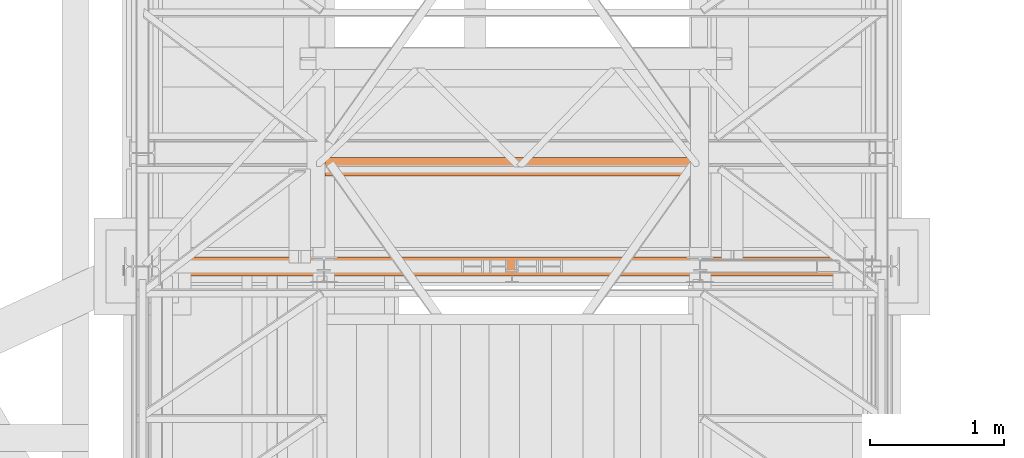
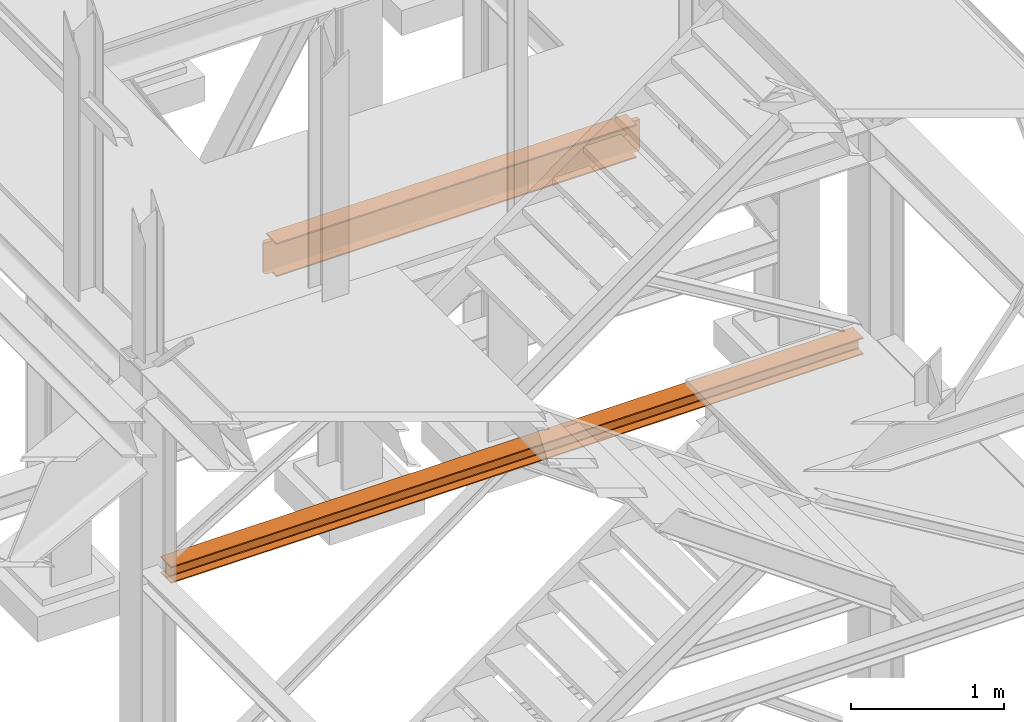
# One storey, part 54 of 208: 2 proxies.
"""IFC2X3 building model written with IfcOpenShell, lengths in millimetres."""

from ifc_helpers import new_model, entity, si_unit, converted_unit, frame, origin, origin_with_axes, place, context, subcontext, project, spatial, faceted_brep, element, save


model = new_model("IFC2X3")

# Units and contexts
model_context = context("Model", 3, precision=1e-05, world=origin())
plan_context = context("Plan", 3, precision=1e-05, world=origin())
body_context = subcontext(model_context, "Body", "Model", "MODEL_VIEW")
ifc_project = project(units=[si_unit("LENGTHUNIT", "METRE", prefix="MILLI"), converted_unit("PLANEANGLEUNIT", "DEGREE", entity("IfcPlaneAngleMeasure", 0.0174532925199433), si_unit("PLANEANGLEUNIT", "RADIAN"), dimensions=[0, 0, 0, 0, 0, 0, 0]), si_unit("AREAUNIT", "SQUARE_METRE"), si_unit("VOLUMEUNIT", "CUBIC_METRE")], contexts=[model_context, plan_context])

# Building, storey
building_placement = place(None, origin())
building = spatial("IfcBuilding", under=ifc_project, at=building_placement, CompositionType="COMPLEX")
storey_placement = place(building_placement, origin_with_axes())
storey = spatial("IfcBuildingStorey", under=building, at=storey_placement, Name="Geschoss", CompositionType="ELEMENT")

# Proxies
proxy_1_placement = place(storey_placement, frame((1333.254973893079, -22132.57439061591, 3447.489998909947), z_axis=(0.0, 0.0, 1.0), x_axis=(1.0, 0.0, 0.0)))
element("IfcBuildingElementProxy", 1, at=proxy_1_placement, inside=storey, context=body_context, shape_type="Brep", body=[
    faceted_brep([(0.01000000000021828, 0.01000000000567525, 8.510002324581365), (0.01000000000021828, 0.01000000000567525, 0.01000000000021828), (0.01000000000021828, 140.0100005960521, 0.01000000000021828), (0.01000000000021828, 140.0100005960521, 8.510002324581365), (0.01000000000021828, 84.76000038743587, 8.510002324581365), (0.01000000000021828, 78.54945996612878, 9.753034839630345), (0.01000000000021828, 74.00303279817672, 14.29946480155013), (0.01000000000021828, 72.76000051595838, 20.51000429153464), (0.01000000000021828, 72.76000051595838, 112.5100007450583), (0.01000000000021828, 74.00303279817672, 118.7205402350428), (0.01000000000021828, 78.54945996612878, 123.2669664716723), (0.01000000000021828, 84.76000038743587, 124.5099989867213), (0.01000000000021828, 140.0100005960521, 124.5099989867213), (0.01000000000021828, 140.0100005960521, 133.0100013113024), (0.01000000000021828, 0.01000000000567525, 133.0100013113024), (0.01000000000021828, 0.01000000000567525, 124.5099989867213), (0.01000000000021828, 55.26000020862193, 124.5099989867213), (0.01000000000021828, 61.47054062992902, 123.2669664716723), (0.01000000000021828, 66.01696779788108, 118.7205402350428), (0.01000000000021828, 67.26000008009942, 112.5100007450583), (0.01000000000021828, 67.26000008009942, 20.51000429153464), (0.01000000000021828, 66.01696779788108, 14.29946480155013), (0.01000000000021828, 61.47054062992902, 9.753034839630345), (0.01000000000021828, 55.26000020862193, 8.510002324581365), (0.01000000000021828, 0.01000000000567525, 0.01000000000021828), (0.01000000000021828, 0.01000000000567525, 8.510002324581365), (5230.009989271167, 0.01000000000203727, 8.510002324581365), (5230.009989271167, 0.01000000000203727, 0.01000000000021828), (0.01000000000021828, 140.0100005960521, 0.01000000000021828), (0.01000000000021828, 0.01000000000567525, 0.01000000000021828), (5230.009989271167, 0.01000000000203727, 0.01000000000021828), (5230.009989271167, 140.0100005960485, 0.01000000000021828), (0.01000000000021828, 140.0100005960521, 8.510002324581365), (0.01000000000021828, 140.0100005960521, 0.01000000000021828), (5230.009989271167, 140.0100005960485, 0.01000000000021828), (5230.009989271167, 140.0100005960485, 8.510002324581365), (0.01000000000021828, 84.76000038743587, 8.510002324581365), (0.01000000000021828, 140.0100005960521, 8.510002324581365), (5230.009989271167, 140.0100005960485, 8.510002324581365), (5230.009989271167, 84.76000038743223, 8.510002324581365), (0.01000000000021828, 78.54945996612878, 9.753034839630345), (0.01000000000021828, 84.76000038743587, 8.510002324581365), (5230.009989271167, 84.76000038743223, 8.510002324581365), (5230.009989271167, 78.54945996612514, 9.753034839630345), (0.01000000000021828, 74.00303279817672, 14.29946480155013), (0.01000000000021828, 78.54945996612878, 9.753034839630345), (5230.009989271167, 78.54945996612514, 9.753034839630345), (5230.009989271167, 74.00303279817308, 14.29946480155013), (0.01000000000021828, 72.76000051595838, 20.51000429153464), (0.01000000000021828, 74.00303279817672, 14.29946480155013), (5230.009989271167, 74.00303279817308, 14.29946480155013), (5230.009989271167, 72.76000051595474, 20.51000429153464), (0.01000000000021828, 72.76000051595838, 112.5100007450583), (0.01000000000021828, 72.76000051595838, 20.51000429153464), (5230.009989271167, 72.76000051595474, 20.51000429153464), (5230.009989271167, 72.76000051595474, 112.5100007450583), (0.01000000000021828, 74.00303279817672, 118.7205402350428), (0.01000000000021828, 72.76000051595838, 112.5100007450583), (5230.009989271167, 72.76000051595474, 112.5100007450583), (5230.009989271167, 74.00303279817308, 118.7205402350428), (0.01000000000021828, 78.54945996612878, 123.2669664716723), (0.01000000000021828, 74.00303279817672, 118.7205402350428), (5230.009989271167, 74.00303279817308, 118.7205402350428), (5230.009989271167, 78.54945996612514, 123.2669664716723), (0.01000000000021828, 84.76000038743587, 124.5099989867213), (0.01000000000021828, 78.54945996612878, 123.2669664716723), (5230.009989271167, 78.54945996612514, 123.2669664716723), (5230.009989271167, 84.76000038743223, 124.5099989867213), (0.01000000000021828, 140.0100005960521, 124.5099989867213), (0.01000000000021828, 84.76000038743587, 124.5099989867213), (5230.009989271167, 84.76000038743223, 124.5099989867213), (5230.009989271167, 140.0100005960485, 124.5099989867213), (0.01000000000021828, 140.0100005960521, 133.0100013113024), (0.01000000000021828, 140.0100005960521, 124.5099989867213), (5230.009989271167, 140.0100005960485, 124.5099989867213), (5230.009989271167, 140.0100005960485, 133.0100013113024), (0.01000000000021828, 0.01000000000567525, 133.0100013113024), (0.01000000000021828, 140.0100005960521, 133.0100013113024), (5230.009989271167, 140.0100005960485, 133.0100013113024), (5230.009989271167, 0.01000000000203727, 133.0100013113024), (0.01000000000021828, 0.01000000000567525, 124.5099989867213), (0.01000000000021828, 0.01000000000567525, 133.0100013113024), (5230.009989271167, 0.01000000000203727, 133.0100013113024), (5230.009989271167, 0.01000000000203727, 124.5099989867213), (0.01000000000021828, 55.26000020862193, 124.5099989867213), (0.01000000000021828, 0.01000000000567525, 124.5099989867213), (5230.009989271167, 0.01000000000203727, 124.5099989867213), (5230.009989271167, 55.26000020861829, 124.5099989867213), (0.01000000000021828, 61.47054062992902, 123.2669664716723), (0.01000000000021828, 55.26000020862193, 124.5099989867213), (5230.009989271167, 55.26000020861829, 124.5099989867213), (5230.009989271167, 61.47054062992538, 123.2669664716723), (0.01000000000021828, 66.01696779788108, 118.7205402350428), (0.01000000000021828, 61.47054062992902, 123.2669664716723), (5230.009989271167, 61.47054062992538, 123.2669664716723), (5230.009989271167, 66.01696779787744, 118.7205402350428), (0.01000000000021828, 67.26000008009942, 112.5100007450583), (0.01000000000021828, 66.01696779788108, 118.7205402350428), (5230.009989271167, 66.01696779787744, 118.7205402350428), (5230.009989271167, 67.26000008009578, 112.5100007450583), (0.01000000000021828, 67.26000008009942, 20.51000429153464), (0.01000000000021828, 67.26000008009942, 112.5100007450583), (5230.009989271167, 67.26000008009578, 112.5100007450583), (5230.009989271167, 67.26000008009578, 20.51000429153464), (0.01000000000021828, 66.01696779788108, 14.29946480155013), (0.01000000000021828, 67.26000008009942, 20.51000429153464), (5230.009989271167, 67.26000008009578, 20.51000429153464), (5230.009989271167, 66.01696779787744, 14.29946480155013), (0.01000000000021828, 61.47054062992902, 9.753034839630345), (0.01000000000021828, 66.01696779788108, 14.29946480155013), (5230.009989271167, 66.01696779787744, 14.29946480155013), (5230.009989271167, 61.47054062992538, 9.753034839630345), (0.01000000000021828, 55.26000020862193, 8.510002324581365), (0.01000000000021828, 61.47054062992902, 9.753034839630345), (5230.009989271167, 61.47054062992538, 9.753034839630345), (5230.009989271167, 55.26000020861829, 8.510002324581365), (0.01000000000021828, 0.01000000000567525, 8.510002324581365), (0.01000000000021828, 55.26000020862193, 8.510002324581365), (5230.009989271167, 55.26000020861829, 8.510002324581365), (5230.009989271167, 0.01000000000203727, 8.510002324581365), (5230.009989271167, 0.01000000000203727, 8.510002324581365), (5230.009989271167, 55.26000020861829, 8.510002324581365), (5230.009989271167, 61.47054062992538, 9.753034839630345), (5230.009989271167, 66.01696779787744, 14.29946480155013), (5230.009989271167, 67.26000008009578, 20.51000429153464), (5230.009989271167, 67.26000008009578, 112.5100007450583), (5230.009989271167, 66.01696779787744, 118.7205402350428), (5230.009989271167, 61.47054062992538, 123.2669664716723), (5230.009989271167, 55.26000020861829, 124.5099989867213), (5230.009989271167, 0.01000000000203727, 124.5099989867213), (5230.009989271167, 0.01000000000203727, 133.0100013113024), (5230.009989271167, 140.0100005960485, 133.0100013113024), (5230.009989271167, 140.0100005960485, 124.5099989867213), (5230.009989271167, 84.76000038743223, 124.5099989867213), (5230.009989271167, 78.54945996612514, 123.2669664716723), (5230.009989271167, 74.00303279817308, 118.7205402350428), (5230.009989271167, 72.76000051595474, 112.5100007450583), (5230.009989271167, 72.76000051595474, 20.51000429153464), (5230.009989271167, 74.00303279817308, 14.29946480155013), (5230.009989271167, 78.54945996612514, 9.753034839630345), (5230.009989271167, 84.76000038743223, 8.510002324581365), (5230.009989271167, 140.0100005960485, 8.510002324581365), (5230.009989271167, 140.0100005960485, 0.01000000000021828), (5230.009989271167, 0.01000000000203727, 0.01000000000021828)], [[[0, 1, 2, 3, 4, 5, 6, 7, 8, 9, 10, 11, 12, 13, 14, 15, 16, 17, 18, 19, 20, 21, 22, 23]], [[24, 25, 26, 27]], [[28, 29, 30, 31]], [[32, 33, 34, 35]], [[36, 37, 38, 39]], [[40, 41, 42, 43]], [[44, 45, 46, 47]], [[48, 49, 50, 51]], [[52, 53, 54, 55]], [[56, 57, 58, 59]], [[60, 61, 62, 63]], [[64, 65, 66, 67]], [[68, 69, 70, 71]], [[72, 73, 74, 75]], [[76, 77, 78, 79]], [[80, 81, 82, 83]], [[84, 85, 86, 87]], [[88, 89, 90, 91]], [[92, 93, 94, 95]], [[96, 97, 98, 99]], [[100, 101, 102, 103]], [[104, 105, 106, 107]], [[108, 109, 110, 111]], [[112, 113, 114, 115]], [[116, 117, 118, 119]], [[120, 121, 122, 123, 124, 125, 126, 127, 128, 129, 130, 131, 132, 133, 134, 135, 136, 137, 138, 139, 140, 141, 142, 143]]], orient=[[False], [False], [False], [False], [False], [False], [False], [False], [False], [False], [False], [False], [False], [False], [False], [False], [False], [False], [False], [False], [False], [False], [False], [False], [False], [False]]),
])
proxy_2_placement = place(storey_placement, frame((2493.538204317862, -21388.07439022289, 5014.990005364415), z_axis=(0.0, 0.0, 1.0), x_axis=(1.0, 0.0, 0.0)))
element("IfcBuildingElementProxy", 2, at=proxy_2_placement, inside=storey, context=body_context, shape_type="Brep", body=[
    faceted_brep([(2783.226764020814, 135.010000000002, 270.0100000000002), (64.21000004768484, 135.0100000000057, 270.0100000000002), (64.21000004768484, 135.0100000000057, 259.8100001907351), (2783.226764020813, 135.010000000002, 259.8100001907351), (2783.226764020813, 135.010000000002, 259.8100001907351), (64.21000004768484, 135.0100000000057, 259.8100001907351), (64.21000004768484, 85.80999995232196, 259.8100001907351), (2783.226764020813, 85.80999995231832, 259.8100001907351), (2832.426764068498, 85.80999995231832, 259.810000190736), (2783.226764020813, 85.80999995231832, 259.8100001907351), (64.21000004768484, 85.80999995232196, 259.8100001907351), (15.01000000000113, 85.80999995232196, 259.8100001907351), (10.37476080785655, 81.17476076017556, 259.0757968253238), (2837.062003260642, 81.17476076017556, 259.0757968253238), (2837.062003260642, 81.17476076017556, 259.0757968253238), (10.37476080785655, 81.17476076017556, 259.0757968253238), (6.193236074556808, 76.99323602687582, 256.9452365592933), (2841.243527993944, 76.99323602687582, 256.9452365592924), (2841.243527993944, 76.99323602687582, 256.9452365592924), (6.193236074556808, 76.99323602687582, 256.9452365592933), (2.874763631445603, 73.6747635837637, 253.6267641161803), (2844.562000437054, 73.6747635837637, 253.6267641161803), (2844.562000437054, 73.6747635837637, 253.6267641161803), (2.874763631445603, 73.6747635837637, 253.6267641161803), (0.7442033654124316, 71.54420331773144, 249.4452393828797), (2846.692560703086, 71.54420331773144, 249.4452393828797), (2846.692560703086, 71.54420331773144, 249.4452393828797), (0.7442033654124316, 71.54420331773144, 249.4452393828797), (0.01000000000112777, 70.80999995232196, 244.8100001907351), (2847.426764068498, 70.80999995231832, 244.8100001907351), (2847.426764068498, 70.80999995231832, 244.8100001907351), (0.01000000000112777, 70.80999995232196, 244.8100001907351), (0.01000000000112777, 70.80999995232196, 25.20999980926536), (2847.426764068498, 70.80999995231832, 25.20999980926536), (2847.426764068498, 70.80999995231832, 25.20999980926536), (0.01000000000112777, 70.80999995232196, 25.20999980926536), (0.7442033654124316, 71.54420331773144, 20.57476061712077), (2846.603718554712, 71.54420331773144, 20.57476061712077), (2846.915607506002, 71.42493642729096, 21.32772715327792), (2846.603718554712, 71.54420331773144, 20.57476061712077), (0.7442033654124316, 71.54420331773144, 20.57476061712077), (2.874763631444694, 73.6747635837637, 16.39323588382013), (2844.406723745758, 73.6747635837637, 16.39323588382013), (2845.41710483617, 73.00383809969208, 17.71002168452014), (2844.406723745758, 73.6747635837637, 16.39323588382013), (2.874763631444694, 73.6747635837637, 16.39323588382013), (6.193236074556808, 76.99323602687582, 13.07476344070892), (2841.041162624857, 76.99323602687582, 13.07476344070892), (2843.033365786296, 75.46460137611575, 14.60339809146717), (2841.041162624857, 76.99323602687582, 13.07476344070892), (6.193236074556808, 76.99323602687582, 13.07476344070892), (10.37476080785655, 81.17476076017556, 10.94420317467666), (2836.847519341127, 81.17476076017556, 10.94420317467666), (2839.926742193244, 78.67149890047949, 12.21965904159242), (2836.847519341127, 81.17476076017556, 10.94420317467666), (10.37476080785655, 81.17476076017556, 10.94420317467666), (15.01000000000113, 85.80999995232196, 10.20999980926536), (64.21000004768484, 85.80999995232196, 10.20999980926536), (2783.226764020814, 85.80999995231832, 10.20999980926536), (2832.426764068498, 85.80999995231832, 10.20999980926536), (2836.309036724484, 82.58292004036775, 10.72115637176194), (2783.226764020814, 85.80999995231832, 10.20999980926536), (64.21000004768484, 85.80999995232196, 10.20999980926536), (64.21000004768484, 135.0100000000057, 10.20999980926536), (2783.226764020814, 135.010000000002, 10.20999980926536), (2783.226764020814, 135.010000000002, 10.20999980926536), (64.21000004768484, 135.0100000000057, 10.20999980926536), (64.21000004768484, 135.0100000000057, 0.01000000000021828), (2783.226764020814, 135.010000000002, 0.01000000000021828), (2783.226764020814, 135.010000000002, 0.01000000000021828), (64.21000004768484, 135.0100000000057, 0.01000000000021828), (64.21000004768484, 0.01000000000567525, 0.01000000000021828), (2783.226764020814, 0.01000000000203727, 0.01000000000021828), (2783.226764020814, 0.01000000000203727, 0.01000000000021828), (64.21000004768484, 0.01000000000567525, 0.01000000000021828), (64.21000004768484, 0.01000000000567525, 10.20999980926536), (2783.226764020814, 0.01000000000203727, 10.20999980926536), (2783.226764020814, 0.01000000000203727, 10.20999980926536), (64.21000004768484, 0.01000000000567525, 10.20999980926536), (64.21000004768484, 49.21000004768939, 10.20999980926536), (2783.226764020814, 49.21000004768575, 10.20999980926536), (2832.426764068498, 49.21000004768575, 10.20999980926536), (2783.226764020814, 49.21000004768575, 10.20999980926536), (64.21000004768484, 49.21000004768939, 10.20999980926536), (15.01000000000113, 49.21000004768939, 10.20999980926536), (11.78292008804874, 53.0922727036741, 10.72115637176194), (2836.309036724484, 53.0922727036741, 10.72115637176194), (2836.309036724484, 53.0922727036741, 10.72115637176194), (11.78292008804874, 53.0922727036741, 10.72115637176194), (10.37476080785655, 53.63075532031871, 10.94420317467757), (7.871498948160479, 56.70997817243551, 12.21965904159242), (2839.926742193244, 56.70997817243188, 12.21965904159242), (2839.926742193244, 56.70997817243188, 12.21965904159242), (7.871498948160479, 56.70997817243551, 12.21965904159242), (6.193236074556808, 57.82439860405066, 13.07476344070892), (4.664601423799468, 59.81660176548758, 14.60339809146717), (2843.033365786296, 59.81660176548394, 14.60339809146717), (2843.033365786296, 59.81660176548394, 14.60339809146717), (4.664601423799468, 59.81660176548758, 14.60339809146717), (2.874763631444694, 61.18995972495031, 16.39323588382013), (2.203838147373972, 62.20034081536142, 17.71002168452014), (2845.41710483617, 62.20034081536142, 17.71002168452014), (2845.41710483617, 62.20034081536142, 17.71002168452014), (2.203838147373972, 62.20034081536142, 17.71002168452014), (0.7442033654124316, 63.38695453390392, 20.57476061712077), (0.6249364749737651, 63.6988434851919, 21.32772715327792), (2846.915607506002, 63.6988434851919, 21.32772715327792), (2846.915607506002, 63.6988434851919, 21.32772715327792), (0.6249364749737651, 63.6988434851919, 21.32772715327792), (0.01000000000021828, 64.21000004768939, 25.20999980926536), (2847.426764068498, 64.21000004768575, 25.20999980926536), (2847.426764068498, 64.21000004768575, 25.20999980926536), (0.01000000000021828, 64.21000004768939, 25.20999980926536), (0.01000000000021828, 64.21000004768939, 244.8100001907351), (2847.426764068498, 64.21000004768575, 244.8100001907351), (2847.426764068498, 64.21000004768575, 244.8100001907351), (0.01000000000021828, 64.21000004768939, 244.8100001907351), (0.7442033654124316, 63.47579668227627, 249.4452393828797), (2846.692560703086, 63.47579668227627, 249.4452393828797), (2846.692560703086, 63.47579668227627, 249.4452393828797), (0.7442033654124316, 63.47579668227627, 249.4452393828797), (2.874763631444694, 61.34523641624401, 253.6267641161803), (2844.562000437054, 61.34523641624401, 253.6267641161803), (2844.562000437054, 61.34523641624401, 253.6267641161803), (2.874763631444694, 61.34523641624401, 253.6267641161803), (6.193236074556808, 58.02676397313553, 256.9452365592933), (2841.243527993944, 58.02676397313189, 256.9452365592924), (2841.243527993944, 58.02676397313189, 256.9452365592924), (6.193236074556808, 58.02676397313553, 256.9452365592933), (10.37476080785655, 53.84523923983215, 259.0757968253238), (2837.062003260642, 53.84523923983215, 259.0757968253238), (2837.062003260642, 53.84523923983215, 259.0757968253238), (10.37476080785655, 53.84523923983215, 259.0757968253238), (15.01000000000113, 49.21000004768939, 259.8100001907351), (64.21000004768484, 49.21000004768939, 259.8100001907351), (2783.226764020814, 49.21000004768575, 259.8100001907351), (2832.426764068498, 49.21000004768575, 259.8100001907351), (2783.226764020814, 49.21000004768575, 259.8100001907351), (64.21000004768484, 49.21000004768939, 259.8100001907351), (64.21000004768484, 0.01000000000567525, 259.8100001907351), (2783.226764020813, 0.01000000000203727, 259.8100001907351), (2783.226764020813, 0.01000000000203727, 259.8100001907351), (64.21000004768484, 0.01000000000567525, 259.8100001907351), (64.21000004768484, 0.01000000000567525, 270.0100000000002), (2783.226764020814, 0.01000000000203727, 270.0100000000002), (2783.226764020814, 0.01000000000203727, 270.0100000000002), (64.21000004768484, 0.01000000000567525, 270.0100000000002), (64.21000004768484, 135.0100000000057, 270.0100000000002), (2783.226764020814, 135.010000000002, 270.0100000000002), (2783.226764020814, 0.01000000000203727, 0.01000000000021828), (2783.226764020814, 0.01000000000203727, 10.20999980926536), (2783.226764020814, 49.21000004768575, 10.20999980926536), (2783.226764020814, 85.80999995231832, 10.20999980926536), (2783.226764020814, 135.010000000002, 10.20999980926536), (2783.226764020814, 135.010000000002, 0.01000000000021828), (2783.226764020814, 49.21000004768575, 10.20999980926536), (2832.426764068498, 49.21000004768575, 10.20999980926536), (2832.426764068498, 85.80999995231832, 10.20999980926536), (2783.226764020814, 85.80999995231832, 10.20999980926536), (2832.426764068498, 49.21000004768575, 10.20999980926536), (2836.309036724484, 53.0922727036741, 10.72115637176194), (2836.309036724484, 82.58292004036775, 10.72115637176194), (2832.426764068498, 85.80999995231832, 10.20999980926536), (2836.309036724484, 53.0922727036741, 10.72115637176194), (2839.926742193244, 56.70997817243188, 12.21965904159242), (2839.926742193244, 78.67149890047949, 12.21965904159242), (2836.847519341127, 81.17476076017556, 10.94420317467666), (2836.309036724484, 82.58292004036775, 10.72115637176194), (2839.926742193244, 56.70997817243188, 12.21965904159242), (2843.033365786296, 59.81660176548394, 14.60339809146717), (2843.033365786296, 75.46460137611575, 14.60339809146717), (2841.041162624857, 76.99323602687582, 13.07476344070892), (2839.926742193244, 78.67149890047949, 12.21965904159242), (2843.033365786296, 59.81660176548394, 14.60339809146717), (2845.41710483617, 62.20034081536142, 17.71002168452014), (2845.41710483617, 73.00383809969208, 17.71002168452014), (2844.406723745758, 73.6747635837637, 16.39323588382013), (2843.033365786296, 75.46460137611575, 14.60339809146717), (2845.41710483617, 62.20034081536142, 17.71002168452014), (2846.915607506002, 63.6988434851919, 21.32772715327792), (2846.915607506002, 71.42493642729096, 21.32772715327792), (2846.603718554712, 71.54420331773144, 20.57476061712077), (2845.41710483617, 73.00383809969208, 17.71002168452014), (2846.915607506002, 63.6988434851919, 21.32772715327792), (2847.426764068498, 64.21000004768575, 25.20999980926536), (2847.426764068498, 70.80999995231832, 25.20999980926536), (2846.915607506002, 71.42493642729096, 21.32772715327792), (2847.426764068498, 64.21000004768575, 25.20999980926536), (2847.426764068498, 64.21000004768575, 244.8100001907351), (2847.426764068498, 70.80999995231832, 244.8100001907351), (2847.426764068498, 70.80999995231832, 25.20999980926536), (2847.426764068498, 64.21000004768575, 244.8100001907351), (2846.692560703086, 63.47579668227627, 249.4452393828797), (2846.692560703086, 71.54420331773144, 249.4452393828797), (2847.426764068498, 70.80999995231832, 244.8100001907351), (2846.692560703086, 63.47579668227627, 249.4452393828797), (2844.562000437054, 61.34523641624401, 253.6267641161803), (2844.562000437054, 73.6747635837637, 253.6267641161803), (2846.692560703086, 71.54420331773144, 249.4452393828797), (2844.562000437054, 61.34523641624401, 253.6267641161803), (2841.243527993944, 58.02676397313189, 256.9452365592924), (2841.243527993944, 76.99323602687582, 256.9452365592924), (2844.562000437054, 73.6747635837637, 253.6267641161803), (2841.243527993944, 58.02676397313189, 256.9452365592924), (2837.062003260642, 53.84523923983215, 259.0757968253238), (2837.062003260642, 81.17476076017556, 259.0757968253238), (2841.243527993944, 76.99323602687582, 256.9452365592924), (2837.062003260642, 53.84523923983215, 259.0757968253238), (2832.426764068498, 49.21000004768575, 259.8100001907351), (2832.426764068498, 85.80999995231832, 259.810000190736), (2837.062003260642, 81.17476076017556, 259.0757968253238), (2832.426764068498, 49.21000004768575, 259.8100001907351), (2783.226764020814, 49.21000004768575, 259.8100001907351), (2783.226764020813, 85.80999995231832, 259.8100001907351), (2832.426764068498, 85.80999995231832, 259.810000190736), (2783.226764020813, 0.01000000000203727, 259.8100001907351), (2783.226764020814, 0.01000000000203727, 270.0100000000002), (2783.226764020814, 135.010000000002, 270.0100000000002), (2783.226764020813, 135.010000000002, 259.8100001907351), (2783.226764020813, 85.80999995231832, 259.8100001907351), (2783.226764020814, 49.21000004768575, 259.8100001907351), (64.21000004768484, 0.01000000000567525, 270.0100000000002), (64.21000004768484, 0.01000000000567525, 259.8100001907351), (64.21000004768484, 49.21000004768939, 259.8100001907351), (64.21000004768484, 85.80999995232196, 259.8100001907351), (64.21000004768484, 135.0100000000057, 259.8100001907351), (64.21000004768484, 135.0100000000057, 270.0100000000002), (64.21000004768484, 49.21000004768939, 259.8100001907351), (15.01000000000113, 49.21000004768939, 259.8100001907351), (15.01000000000113, 85.80999995232196, 259.8100001907351), (64.21000004768484, 85.80999995232196, 259.8100001907351), (15.01000000000113, 49.21000004768939, 259.8100001907351), (10.37476080785655, 53.84523923983215, 259.0757968253238), (10.37476080785655, 81.17476076017556, 259.0757968253238), (15.01000000000113, 85.80999995232196, 259.8100001907351), (10.37476080785655, 53.84523923983215, 259.0757968253238), (6.193236074556808, 58.02676397313553, 256.9452365592933), (6.193236074556808, 76.99323602687582, 256.9452365592933), (10.37476080785655, 81.17476076017556, 259.0757968253238), (6.193236074556808, 58.02676397313553, 256.9452365592933), (2.874763631444694, 61.34523641624401, 253.6267641161803), (2.874763631445603, 73.6747635837637, 253.6267641161803), (6.193236074556808, 76.99323602687582, 256.9452365592933), (2.874763631444694, 61.34523641624401, 253.6267641161803), (0.7442033654124316, 63.47579668227627, 249.4452393828797), (0.7442033654124316, 71.54420331773144, 249.4452393828797), (2.874763631445603, 73.6747635837637, 253.6267641161803), (0.7442033654124316, 63.47579668227627, 249.4452393828797), (0.01000000000021828, 64.21000004768939, 244.8100001907351), (0.01000000000112777, 70.80999995232196, 244.8100001907351), (0.7442033654124316, 71.54420331773144, 249.4452393828797), (0.01000000000021828, 64.21000004768939, 244.8100001907351), (0.01000000000021828, 64.21000004768939, 25.20999980926536), (0.01000000000112777, 70.80999995232196, 25.20999980926536), (0.01000000000112777, 70.80999995232196, 244.8100001907351), (0.01000000000021828, 64.21000004768939, 25.20999980926536), (0.6249364749737651, 63.6988434851919, 21.32772715327792), (0.7442033654124316, 63.38695453390392, 20.57476061712077), (0.7442033654124316, 71.54420331773144, 20.57476061712077), (0.01000000000112777, 70.80999995232196, 25.20999980926536), (0.7442033654124316, 63.38695453390392, 20.57476061712077), (2.203838147373972, 62.20034081536142, 17.71002168452014), (2.874763631444694, 61.18995972495031, 16.39323588382013), (2.874763631444694, 73.6747635837637, 16.39323588382013), (0.7442033654124316, 71.54420331773144, 20.57476061712077), (2.874763631444694, 61.18995972495031, 16.39323588382013), (4.664601423799468, 59.81660176548758, 14.60339809146717), (6.193236074556808, 57.82439860405066, 13.07476344070892), (6.193236074556808, 76.99323602687582, 13.07476344070892), (2.874763631444694, 73.6747635837637, 16.39323588382013), (6.193236074556808, 57.82439860405066, 13.07476344070892), (7.871498948160479, 56.70997817243551, 12.21965904159242), (10.37476080785655, 53.63075532031871, 10.94420317467757), (10.37476080785655, 81.17476076017556, 10.94420317467666), (6.193236074556808, 76.99323602687582, 13.07476344070892), (10.37476080785655, 53.63075532031871, 10.94420317467757), (11.78292008804874, 53.0922727036741, 10.72115637176194), (15.01000000000113, 49.21000004768939, 10.20999980926536), (15.01000000000113, 85.80999995232196, 10.20999980926536), (10.37476080785655, 81.17476076017556, 10.94420317467666), (15.01000000000113, 49.21000004768939, 10.20999980926536), (64.21000004768484, 49.21000004768939, 10.20999980926536), (64.21000004768484, 85.80999995232196, 10.20999980926536), (15.01000000000113, 85.80999995232196, 10.20999980926536), (64.21000004768484, 0.01000000000567525, 10.20999980926536), (64.21000004768484, 0.01000000000567525, 0.01000000000021828), (64.21000004768484, 135.0100000000057, 0.01000000000021828), (64.21000004768484, 135.0100000000057, 10.20999980926536), (64.21000004768484, 85.80999995232196, 10.20999980926536), (64.21000004768484, 49.21000004768939, 10.20999980926536)], [[[0, 1, 2, 3]], [[4, 5, 6, 7]], [[8, 9, 10, 11, 12, 13]], [[14, 15, 16, 17]], [[18, 19, 20, 21]], [[22, 23, 24, 25]], [[26, 27, 28, 29]], [[30, 31, 32, 33]], [[34, 35, 36, 37, 38]], [[39, 40, 41, 42, 43]], [[44, 45, 46, 47, 48]], [[49, 50, 51, 52, 53]], [[54, 55, 56, 57, 58, 59, 60]], [[61, 62, 63, 64]], [[65, 66, 67, 68]], [[69, 70, 71, 72]], [[73, 74, 75, 76]], [[77, 78, 79, 80]], [[81, 82, 83, 84, 85, 86]], [[87, 88, 89, 90, 91]], [[92, 93, 94, 95, 96]], [[97, 98, 99, 100, 101]], [[102, 103, 104, 105, 106]], [[107, 108, 109, 110]], [[111, 112, 113, 114]], [[115, 116, 117, 118]], [[119, 120, 121, 122]], [[123, 124, 125, 126]], [[127, 128, 129, 130]], [[131, 132, 133, 134, 135, 136]], [[137, 138, 139, 140]], [[141, 142, 143, 144]], [[145, 146, 147, 148]], [[149, 150, 151, 152, 153, 154]], [[155, 156, 157, 158]], [[159, 160, 161, 162]], [[163, 164, 165, 166, 167]], [[168, 169, 170, 171, 172]], [[173, 174, 175, 176, 177]], [[178, 179, 180, 181, 182]], [[183, 184, 185, 186]], [[187, 188, 189, 190]], [[191, 192, 193, 194]], [[195, 196, 197, 198]], [[199, 200, 201, 202]], [[203, 204, 205, 206]], [[207, 208, 209, 210]], [[211, 212, 213, 214]], [[215, 216, 217, 218, 219, 220]], [[221, 222, 223, 224, 225, 226]], [[227, 228, 229, 230]], [[231, 232, 233, 234]], [[235, 236, 237, 238]], [[239, 240, 241, 242]], [[243, 244, 245, 246]], [[247, 248, 249, 250]], [[251, 252, 253, 254]], [[255, 256, 257, 258, 259]], [[260, 261, 262, 263, 264]], [[265, 266, 267, 268, 269]], [[270, 271, 272, 273, 274]], [[275, 276, 277, 278, 279]], [[280, 281, 282, 283]], [[284, 285, 286, 287, 288, 289]]], orient=[[False], [False], [False], [False], [False], [False], [False], [False], [False], [False], [False], [False], [False], [False], [False], [False], [False], [False], [False], [False], [False], [False], [False], [False], [False], [False], [False], [False], [False], [False], [False], [False], [False], [False], [False], [False], [False], [False], [False], [False], [False], [False], [False], [False], [False], [False], [False], [False], [False], [False], [False], [False], [False], [False], [False], [False], [False], [False], [False], [False], [False], [False], [False], [False]]),
])

save(model, "model.ifc")
